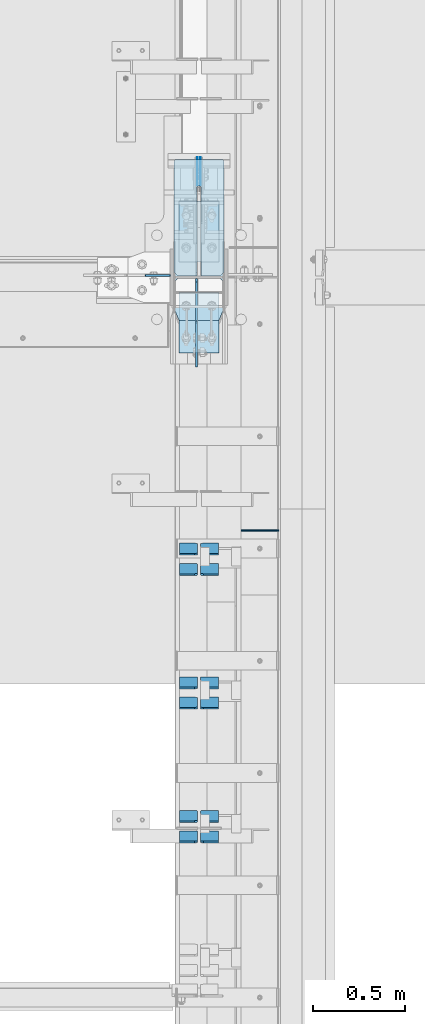
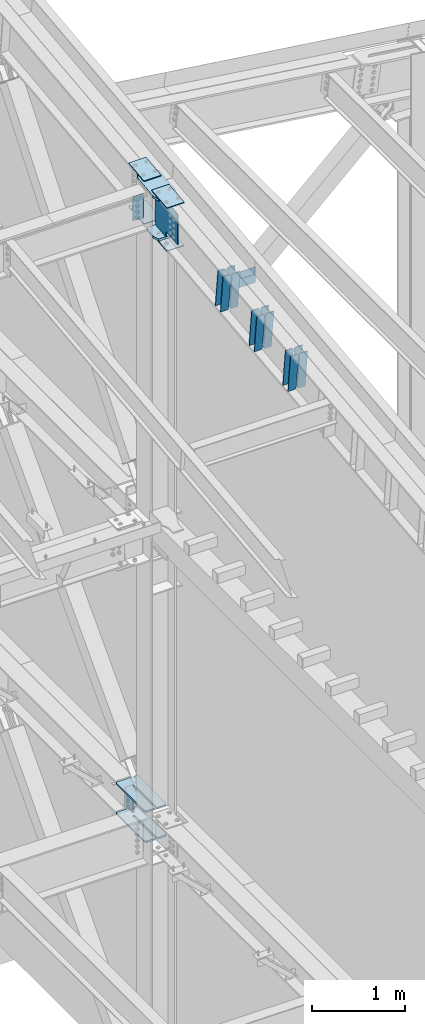
# One storey, part 1044 of 1179: 25 plates, 4 elements without a shape of their own.
"""IFC2X3 building model written with IfcOpenShell, lengths in millimetres."""

from ifc_helpers import new_model, si_unit, frame, origin_with_axes, place, context, subcontext, project, spatial, faceted_brep, material, type_object, element, aggregate, save


model = new_model("IFC2X3")

# Units and contexts
model_context = context("Model", 3, precision=1e-05, world=origin_with_axes())
body_context = subcontext(model_context, "Body", "Model", "MODEL_VIEW")
ifc_project = project(units=[si_unit("LENGTHUNIT", "METRE", prefix="MILLI"), si_unit("AREAUNIT", "SQUARE_METRE"), si_unit("VOLUMEUNIT", "CUBIC_METRE"), si_unit("MASSUNIT", "GRAM", prefix="KILO"), si_unit("TIMEUNIT", "SECOND"), si_unit("PLANEANGLEUNIT", "RADIAN"), si_unit("SOLIDANGLEUNIT", "STERADIAN"), si_unit("THERMODYNAMICTEMPERATUREUNIT", "DEGREE_CELSIUS"), si_unit("LUMINOUSINTENSITYUNIT", "LUMEN")], contexts=[model_context])

# Site, building, storey
site_placement = place(None, origin_with_axes())
site = spatial("IfcSite", under=ifc_project, at=site_placement, CompositionType="ELEMENT")
building_placement = place(site_placement, origin_with_axes())
building = spatial("IfcBuilding", under=site, at=building_placement, Name="Undefined", CompositionType="ELEMENT")
storey_placement = place(building_placement, origin_with_axes())
storey = spatial("IfcBuildingStorey", under=building, at=storey_placement, Name="Undefined", CompositionType="ELEMENT", Elevation=0.0)

# Assembly, plates
assembly_1_placement = place(storey_placement, origin_with_axes())
assembly_1 = element("IfcElementAssembly", 1, at=assembly_1_placement, inside=storey, Name="COLUMN", AssemblyPlace="NOTDEFINED", PredefinedType="RIGID_FRAME")
ifc_material_1 = material(Name="STEEL/A572-GR.50")
plate_type_1 = type_object("IfcPlateType", PredefinedType="NOTDEFINED")
plate_1_placement = place(assembly_1_placement, frame((24171.275012207, 27690.983001131, 3694.1125), z_axis=(0.0, -1.0, 0.0), x_axis=(1.0, 0.0, 0.0)))
plate_1 = element("IfcPlate", 2, at=plate_1_placement, type_object=plate_type_1, material=ifc_material_1, Name="PLATE", context=body_context, shape_type="Brep", body=[
    faceted_brep([(125.412487792972, -11.1125000000002, 633.633001130984), (125.412487792968, -11.1125000000002, 153.987500190735), (125.412487792968, 11.1125000000002, 153.987500190735), (125.412487792972, 11.1125000000002, 633.633001130984), (126.258376502454, -11.1125000000002, 149.734930475586), (126.258376502454, 11.1125000000002, 149.734930475586), (128.667263742896, -11.1125000000002, 146.12977594993), (128.667263742896, 11.1125000000002, 146.12977594993), (132.272418268556, -11.1125000000002, 143.720888709488), (132.272418268556, 11.1125000000002, 143.720888709488), (136.524987602239, -11.1125000000002, 142.875), (136.524987602239, 11.1125000000002, 142.875), (140.777557317386, -11.1125000000002, 143.720888709488), (140.777557317386, 11.1125000000002, 143.720888709488), (144.382711843045, -11.1125000000002, 146.12977594993), (144.382711843045, 11.1125000000002, 146.12977594993), (146.791599083488, -11.1125000000002, 149.734930475586), (146.791599083488, 11.1125000000002, 149.734930475586), (147.637487792974, -11.1125000000002, 153.987500190735), (147.637487792974, 11.1125000000002, 153.987500190735), (147.637487792977, -11.1125000000002, 633.633001130984), (147.637487792977, 11.1125000000002, 633.633001130984), (0.0, -11.1125000000002, 611.408000749514), (22.2250003814697, -11.1125000000002, 633.633001130984), (22.2250003814697, 11.1125000000002, 633.633001130984), (0.0, 11.1125000000002, 611.408000749514), (0.0, -11.1125000000002, 15.875), (0.0, 11.1125000000002, 15.875), (6.34999990463257, -11.1125000000002, 0.0), (6.34999990463257, 11.1125000000002, 0.0), (266.699987888336, -11.1125000000002, 0.0), (266.699987888336, 11.1125000000002, 0.0), (273.049987792969, -11.1125000000002, 15.875), (273.049987792969, 11.1125000000002, 15.875), (273.049987792969, -11.1125000000002, 611.408000749514), (273.049987792969, 11.1125000000002, 611.408000749514), (250.824987411499, -11.1125000000002, 633.633001130984), (250.824987411499, 11.1125000000002, 633.633001130984)], [[[0, 1, 2, 3]], [[4, 5, 2, 1]], [[6, 7, 5, 4]], [[8, 9, 7, 6]], [[10, 11, 9, 8]], [[12, 13, 11, 10]], [[14, 15, 13, 12]], [[16, 17, 15, 14]], [[18, 19, 17, 16]], [[20, 21, 19, 18]], [[22, 23, 24, 25]], [[26, 22, 25, 27]], [[28, 26, 27, 29]], [[30, 28, 29, 31]], [[32, 30, 31, 33]], [[34, 32, 33, 35]], [[36, 34, 35, 37]], [[16, 14, 12, 10, 8, 6, 4, 1, 0, 23, 22, 26, 28, 30, 32, 34, 36, 20, 18]], [[24, 23, 0, 3]], [[37, 35, 33, 31, 29, 27, 25, 24, 3, 2, 5, 7, 9, 11, 13, 15, 17, 19, 21]], [[36, 37, 21, 20]]]),
])
plate_2_placement = place(assembly_1_placement, frame((24171.275012207, 27690.983001131, 4090.9875), z_axis=(0.0, -1.0, 0.0), x_axis=(1.0, 0.0, 0.0)))
plate_2 = element("IfcPlate", 3, at=plate_2_placement, type_object=plate_type_1, material=ifc_material_1, Name="PLATE", context=body_context, shape_type="Brep", body=[
    faceted_brep([(125.412487792972, -11.1125000000002, 633.633001130984), (125.412487792968, -11.1125000000002, 153.987500190735), (125.412487792968, 11.1125000000002, 153.987500190735), (125.412487792972, 11.1125000000002, 633.633001130984), (126.258376502454, -11.1125000000002, 149.734930475586), (126.258376502454, 11.1125000000002, 149.734930475586), (128.667263742896, -11.1125000000002, 146.12977594993), (128.667263742896, 11.1125000000002, 146.12977594993), (132.272418268556, -11.1125000000002, 143.720888709488), (132.272418268556, 11.1125000000002, 143.720888709488), (136.524987602239, -11.1125000000002, 142.875), (136.524987602239, 11.1125000000002, 142.875), (140.777557317386, -11.1125000000002, 143.720888709488), (140.777557317386, 11.1125000000002, 143.720888709488), (144.382711843045, -11.1125000000002, 146.12977594993), (144.382711843045, 11.1125000000002, 146.12977594993), (146.791599083488, -11.1125000000002, 149.734930475586), (146.791599083488, 11.1125000000002, 149.734930475586), (147.637487792974, -11.1125000000002, 153.987500190735), (147.637487792974, 11.1125000000002, 153.987500190735), (147.637487792977, -11.1125000000002, 633.633001130984), (147.637487792977, 11.1125000000002, 633.633001130984), (0.0, -11.1125000000002, 611.408000749514), (22.2250003814697, -11.1125000000002, 633.633001130984), (22.2250003814697, 11.1125000000002, 633.633001130984), (0.0, 11.1125000000002, 611.408000749514), (0.0, -11.1125000000002, 15.875), (0.0, 11.1125000000002, 15.875), (6.34999990463257, -11.1125000000002, 0.0), (6.34999990463257, 11.1125000000002, 0.0), (266.699987888336, -11.1125000000002, 0.0), (266.699987888336, 11.1125000000002, 0.0), (273.049987792969, -11.1125000000002, 15.875), (273.049987792969, 11.1125000000002, 15.875), (273.049987792969, -11.1125000000002, 611.408000749514), (273.049987792969, 11.1125000000002, 611.408000749514), (250.824987411499, -11.1125000000002, 633.633001130984), (250.824987411499, 11.1125000000002, 633.633001130984)], [[[0, 1, 2, 3]], [[4, 5, 2, 1]], [[6, 7, 5, 4]], [[8, 9, 7, 6]], [[10, 11, 9, 8]], [[12, 13, 11, 10]], [[14, 15, 13, 12]], [[16, 17, 15, 14]], [[18, 19, 17, 16]], [[20, 21, 19, 18]], [[22, 23, 24, 25]], [[26, 22, 25, 27]], [[28, 26, 27, 29]], [[30, 28, 29, 31]], [[32, 30, 31, 33]], [[34, 32, 33, 35]], [[36, 34, 35, 37]], [[16, 14, 12, 10, 8, 6, 4, 1, 0, 23, 22, 26, 28, 30, 32, 34, 36, 20, 18]], [[24, 23, 0, 3]], [[37, 35, 33, 31, 29, 27, 25, 24, 3, 2, 5, 7, 9, 11, 13, 15, 17, 19, 21]], [[36, 37, 21, 20]]]),
])
ifc_material_2 = material(Name="STEEL/A36")
plate_type_2 = type_object("IfcPlateType", PredefinedType="NOTDEFINED")
plate_3_placement = place(assembly_1_placement, frame((24150.6375, 27061.3187499701, 12224.9406250357), z_axis=(-1.0, 0.0, 0.0), x_axis=(0.0, 0.0, -1.0)))
plate_3 = element("IfcPlate", 4, at=plate_3_placement, type_object=plate_type_2, material=ifc_material_2, Name="PLATE", context=body_context, shape_type="Brep", body=[
    faceted_brep([(0.0, -4.76249999999709, 0.0), (0.0, -4.76250000000073, 133.35), (0.0, 4.76250000000073, 133.35), (0.0, 4.76249999999709, 0.0), (317.5, -4.76250000000073, 133.350000816426), (317.5, 4.76250000000073, 133.350000816426), (317.499990657736, -4.76249999986703, 5.00222085975111e-10), (317.499990657721, 4.76250000013533, 5.00222085975111e-10)], [[[0, 1, 2, 3]], [[1, 4, 5, 2]], [[4, 6, 7, 5]], [[6, 0, 3, 7]], [[5, 7, 3, 2]], [[6, 4, 1, 0]]]),
])

# Assembly, plate
assembly_2_placement = place(storey_placement, origin_with_axes())
assembly_2 = element("IfcElementAssembly", 5, at=assembly_2_placement, inside=storey, Name="BEAM", AssemblyPlace="NOTDEFINED", PredefinedType="RIGID_FRAME")
plate_type_3 = type_object("IfcPlateType", PredefinedType="NOTDEFINED")
plate_4_placement = place(assembly_2_placement, frame((24739.6, 25676.225, 11892.1378746291), z_axis=(0.0, 0.0, -1.0), x_axis=(-1.0, 0.0, 0.0)))
plate_4 = element("IfcPlate", 6, at=plate_4_placement, type_object=plate_type_3, material=ifc_material_2, Name="CAP_PLATE", context=body_context, shape_type="Brep", body=[
    faceted_brep([(0.0, -3.17500000000109, 0.0), (0.0, -3.17499999999927, 204.492999998953), (0.0, 3.17499999999927, 204.492999998953), (0.0, 3.17500000000109, 7.27595761418343e-12), (203.199999999997, -3.17499999999927, 204.492999998953), (203.199999999997, 3.17499999999927, 204.492999998953), (203.199999999997, -3.17499999999927, 3.63797880709171e-12), (203.199999999997, 3.17499999999382, -3.63797880709171e-12)], [[[0, 1, 2, 3]], [[1, 4, 5, 2]], [[4, 6, 7, 5]], [[6, 0, 3, 7]], [[5, 7, 3, 2]], [[6, 4, 1, 0]]]),
])
aggregate(assembly_2, [plate_4])

# Plate
plate_type_4 = type_object("IfcPlateType", PredefinedType="NOTDEFINED")
plate_5_placement = place(assembly_1_placement, frame((24171.2749999998, 26814.313913095, 12262.513158819), z_axis=(1.0, 0.0, 0.0), x_axis=(0.0, 0.993683229349742, 0.112221387039499)))
plate_5 = element("IfcPlate", 7, at=plate_5_placement, type_object=plate_type_4, material=ifc_material_1, Name="PLATE", context=body_context, shape_type="Brep", body=[
    faceted_brep([(404.009737741189, -14.2874999996602, 8.31619217933621e-11), (71.43750000002, -14.287499999984, 2.90469870378729e-11), (71.4375000000155, 14.2874999999949, 2.90469870378729e-11), (404.009737741166, 14.2875000003405, 8.31619217933621e-11), (477.034739267168, 14.2875000004005, 30.162500381568), (473.810043726306, -14.287499999602, 28.8305609300143), (477.034739268025, 14.2875000004024, 242.887499623284), (473.810043726306, -14.287499999602, 244.219439075195), (404.009737742264, 14.2875000003405, 273.05000000474), (404.00973774229, -14.2874999996602, 273.05000000474), (71.4375000016116, -14.2874999999858, 273.049999999798), (71.4375000016071, 14.2874999999967, 273.049999999798), (4.20644072178584, 14.2875000000058, 244.663552394444), (0.979329666730337, -14.2874999999967, 243.30099437618), (0.979329666730337, -14.2874999999967, 29.7490056281208), (4.20644072178584, 14.2875000000058, 28.3864476098539)], [[[0, 1, 2, 3]], [[0, 3, 4, 5]], [[5, 4, 6, 7]], [[8, 9, 7, 6]], [[10, 9, 8, 11]], [[10, 11, 12, 13]], [[1, 0, 5, 7, 9, 10, 13, 14]], [[2, 1, 14, 15]], [[11, 8, 6, 4, 3, 2, 15, 12]], [[14, 13, 12, 15]]]),
])

# Assembly, plates
assembly_3_placement = place(storey_placement, origin_with_axes())
assembly_3 = element("IfcElementAssembly", 8, at=assembly_3_placement, inside=storey, Name="BEAM", AssemblyPlace="NOTDEFINED", PredefinedType="RIGID_FRAME")
plate_type_5 = type_object("IfcPlateType", PredefinedType="NOTDEFINED")
plate_6_placement = place(assembly_3_placement, frame((24300.65625, 27703.683001131, 4044.95), z_axis=(0.0, 0.0, -1.0), x_axis=(0.0, -1.0, 0.0)))
plate_6 = element("IfcPlate", 9, at=plate_6_placement, type_object=plate_type_5, material=ifc_material_1, Name="PLATE", context=body_context, shape_type="Brep", body=[
    faceted_brep([(3.63797880709171e-12, -1.58750000000055, 1.81898940354586e-12), (-2.18278728425503e-11, -1.58750000000146, 304.8), (-2.18278728425503e-11, 1.58750000000146, 304.8), (-3.63797880709171e-12, 1.58750000000055, 0.0), (152.399999999994, -1.58750000000146, 304.8), (152.399999999994, 1.58750000000146, 304.8), (152.399999999994, -1.58750000000146, 0.0), (152.399999999994, 1.58750000000146, 0.0)], [[[0, 1, 2, 3]], [[1, 4, 5, 2]], [[4, 6, 7, 5]], [[6, 0, 3, 7]], [[5, 7, 3, 2]], [[6, 4, 1, 0]]]),
])
plate_7_placement = place(assembly_3_placement, frame((24314.94375, 27703.683001131, 4044.95), z_axis=(0.0, 0.0, -1.0), x_axis=(0.0, -1.0, 0.0)))
plate_7 = element("IfcPlate", 10, at=plate_7_placement, type_object=plate_type_5, material=ifc_material_1, Name="PLATE", context=body_context, shape_type="Brep", body=[
    faceted_brep([(3.63797880709171e-12, -1.58750000000055, 1.81898940354586e-12), (-2.18278728425503e-11, -1.58750000000146, 304.8), (-2.18278728425503e-11, 1.58750000000146, 304.8), (-3.63797880709171e-12, 1.58750000000055, 0.0), (152.399999999994, -1.58750000000146, 304.8), (152.399999999994, 1.58750000000146, 304.8), (152.399999999994, -1.58750000000146, 0.0), (152.399999999994, 1.58750000000146, 0.0)], [[[0, 1, 2, 3]], [[1, 4, 5, 2]], [[4, 6, 7, 5]], [[6, 0, 3, 7]], [[5, 7, 3, 2]], [[6, 4, 1, 0]]]),
])
aggregate(assembly_3, [plate_6, plate_7])

# Plate
plate_type_6 = type_object("IfcPlateType", PredefinedType="NOTDEFINED")
plate_8_placement = place(assembly_1_placement, frame((24199.850003078, 27462.0732407573, 12356.4484011609), z_axis=(1.0, 0.0, 0.0), x_axis=(0.0, -0.993676146336441, -0.112284087038017)))
plate_8 = element("IfcPlate", 11, at=plate_8_placement, type_object=plate_type_6, material=ifc_material_1, Name="PLATE", context=body_context, shape_type="Brep", body=[
    faceted_brep([(0.0, -6.34999999999854, 0.0), (0.0, -6.350000000004, 215.899993896484), (0.0, 6.35000000000582, 215.899993896484), (0.0, 6.34999999999854, 0.0), (330.200000001782, -6.34999999994034, 215.899993896483), (330.200000001782, 6.35000000006767, 215.899993896483), (330.200000001782, -6.34999999994034, -1.47792889038101e-12), (330.200000001782, 6.35000000006767, -1.47792889038101e-12)], [[[0, 1, 2, 3]], [[1, 4, 5, 2]], [[4, 6, 7, 5]], [[6, 0, 3, 7]], [[5, 7, 3, 2]], [[6, 4, 1, 0]]]),
])

plate_9_placement = place(assembly_1_placement, frame((24199.8500030614, 27463.4992486585, 11791.0580730736), z_axis=(1.0, 0.0, 0.0), x_axis=(0.0, -0.993676146336441, -0.112284087038017)))
plate_9 = element("IfcPlate", 12, at=plate_9_placement, type_object=plate_type_6, material=ifc_material_1, Name="PLATE", context=body_context, shape_type="Brep", body=[
    faceted_brep([(0.0, -6.34999999999854, 0.0), (0.0, -6.350000000004, 215.899993896484), (0.0, 6.35000000000582, 215.899993896484), (0.0, 6.34999999999854, 0.0), (330.200000001782, -6.34999999994034, 215.899993896483), (330.200000001782, 6.35000000006767, 215.899993896483), (330.200000001782, -6.34999999994034, -1.47792889038101e-12), (330.200000001782, 6.35000000006767, -1.47792889038101e-12)], [[[0, 1, 2, 3]], [[1, 4, 5, 2]], [[4, 6, 7, 5]], [[6, 0, 3, 7]], [[5, 7, 3, 2]], [[6, 4, 1, 0]]]),
])

plate_10_placement = place(assembly_1_placement, frame((24199.8500030684, 26640.0882512744, 12263.5651872294), z_axis=(1.0, 0.0, 0.0), x_axis=(0.0, 0.993676146336441, 0.112284087038017)))
plate_10 = element("IfcPlate", 13, at=plate_10_placement, type_object=plate_type_6, material=ifc_material_1, Name="PLATE", context=body_context, shape_type="Brep", body=[
    faceted_brep([(0.0, -6.34999999999854, 0.0), (0.0, -6.350000000004, 215.899993896484), (0.0, 6.35000000000582, 215.899993896484), (0.0, 6.34999999999854, 0.0), (330.200000001782, -6.34999999994034, 215.899993896483), (330.200000001782, 6.35000000006767, 215.899993896483), (330.200000001782, -6.34999999994034, -1.47792889038101e-12), (330.200000001782, 6.35000000006767, -1.47792889038101e-12)], [[[0, 1, 2, 3]], [[1, 4, 5, 2]], [[4, 6, 7, 5]], [[6, 0, 3, 7]], [[5, 7, 3, 2]], [[6, 4, 1, 0]]]),
])

plate_11_placement = place(assembly_1_placement, frame((24199.8500030415, 26640.7392708393, 11698.0872863537), z_axis=(1.0, 0.0, 0.0), x_axis=(0.0, 0.993676146336441, 0.112284087038017)))
plate_11 = element("IfcPlate", 14, at=plate_11_placement, type_object=plate_type_6, material=ifc_material_1, Name="PLATE", context=body_context, shape_type="Brep", body=[
    faceted_brep([(0.0, -6.34999999999854, 0.0), (0.0, -6.350000000004, 215.899993896484), (0.0, 6.35000000000582, 215.899993896484), (0.0, 6.34999999999854, 0.0), (330.200000001782, -6.34999999994034, 215.899993896483), (330.200000001782, 6.35000000006767, 215.899993896483), (330.200000001782, -6.34999999994034, -1.47792889038101e-12), (330.200000001782, 6.35000000006767, -1.47792889038101e-12)], [[[0, 1, 2, 3]], [[1, 4, 5, 2]], [[4, 6, 7, 5]], [[6, 0, 3, 7]], [[5, 7, 3, 2]], [[6, 4, 1, 0]]]),
])

plate_type_7 = type_object("IfcPlateType", PredefinedType="NOTDEFINED")
plate_12_placement = place(assembly_1_placement, frame((24171.2749999998, 26814.3139131717, 11738.3789032815), z_axis=(1.0, 0.0, 0.0), x_axis=(0.0, 0.993676146336441, 0.112284087038017)))
plate_12 = element("IfcPlate", 15, at=plate_12_placement, type_object=plate_type_7, material=ifc_material_1, Name="PLATE", context=body_context, shape_type="Brep", body=[
    faceted_brep([(207.962499617965, -14.2875000000749, 8.87325768417213e-11), (71.43750000002, -14.287499999984, 2.90469870378729e-11), (71.4375000000155, 14.2874999999949, 2.90469870378729e-11), (207.962499617975, 14.2874999999094, 8.87325768417213e-11), (230.187499999511, -14.287500000084, 22.225000381568), (230.187499999523, 14.2874999999003, 22.225000381568), (230.187500000431, -14.2875000000822, 250.824999623284), (230.187500000442, 14.2874999998985, 250.824999623284), (207.962499619063, -14.2875000000731, 273.050000004745), (207.962499619074, 14.2874999999112, 273.050000004745), (71.4375000016116, -14.2874999999858, 273.049999999798), (71.4375000016071, 14.2874999999967, 273.049999999798), (4.20737223302058, 14.2874999999931, 244.663945699182), (0.978435120117865, -14.2874999999894, 243.300616678719), (0.978435120117865, -14.2874999999894, 29.7493833255772), (4.20737223302058, 14.2874999999931, 28.3860543051127)], [[[0, 1, 2, 3]], [[4, 0, 3, 5]], [[6, 4, 5, 7]], [[8, 6, 7, 9]], [[10, 8, 9, 11]], [[10, 11, 12, 13]], [[1, 0, 4, 6, 8, 10, 13, 14]], [[2, 1, 14, 15]], [[11, 9, 7, 5, 3, 2, 15, 12]], [[14, 13, 12, 15]]]),
])

# Assembly, plates
assembly_4_placement = place(storey_placement, origin_with_axes())
assembly_4 = element("IfcElementAssembly", 16, at=assembly_4_placement, inside=storey, Name="BEAM", AssemblyPlace="NOTDEFINED", PredefinedType="RIGID_FRAME")
plate_type_8 = type_object("IfcPlateType", PredefinedType="NOTDEFINED")
plate_13_placement = place(assembly_4_placement, frame((24414.1625, 24040.3832307645, 11436.2025622401), z_axis=(0.0, -0.112284087038017, 0.993676146336441), x_axis=(-1.0, 0.0, 0.0)))
plate_13 = element("IfcPlate", 17, at=plate_13_placement, type_object=plate_type_8, material=ifc_material_2, Name="PLATE", context=body_context, shape_type="Brep", body=[
    faceted_brep([(0.0, -4.76249999999709, 0.0), (0.0, -4.76250000020082, 498.474999998594), (0.0, 4.76249999979336, 498.474999998596), (0.0, 4.76249999999709, 0.0), (81.7562503814697, -4.76250000020082, 498.474999998594), (81.7562503814697, 4.76249999979336, 498.474999998596), (99.21875, -4.76250000019354, 481.012500380073), (99.21875, 4.76249999980064, 481.012500380079), (99.21875, -4.76250000000437, 17.4624996185212), (99.21875, 4.76249999998981, 17.4624996185248), (81.7562503814697, -4.76250000000073, 0.0), (81.7562503814697, 4.76249999999709, 3.63797880709171e-12)], [[[0, 1, 2, 3]], [[1, 4, 5, 2]], [[4, 6, 7, 5]], [[6, 8, 9, 7]], [[8, 10, 11, 9]], [[10, 0, 3, 11]], [[5, 7, 9, 11, 3, 2]], [[10, 8, 6, 4, 1, 0]]]),
])
plate_14_placement = place(assembly_4_placement, frame((24300.65625, 24040.3832307645, 11436.2025622401), z_axis=(0.0, -0.112284087038017, 0.993676146336441), x_axis=(-1.0, 0.0, 0.0)))
plate_14 = element("IfcPlate", 18, at=plate_14_placement, type_object=plate_type_8, material=ifc_material_2, Name="PLATE", context=body_context, shape_type="Brep", body=[
    faceted_brep([(-1.81898940354586e-12, -4.76249999999345, 17.4624996185303), (0.0, -4.76250000019354, 481.012500380073), (0.0, 4.76249999980064, 481.012500380079), (1.81898940354586e-12, 4.76250000000073, 17.4624996185303), (17.4624996185303, -4.76250000020082, 498.474999998594), (17.4624996185303, 4.76249999979336, 498.474999998596), (99.2187497618652, -4.76249999998072, 498.475), (99.2187499999927, 4.76250000001892, 498.475), (99.21875, -4.76250000000073, 0.0), (99.21875, 4.76249999999709, 3.63797880709171e-12), (17.4624996185157, -4.76250000000073, 0.0), (17.4624996185212, 4.76249999999345, 0.0)], [[[0, 1, 2, 3]], [[1, 4, 5, 2]], [[4, 6, 7, 5]], [[6, 8, 9, 7]], [[8, 10, 11, 9]], [[10, 0, 3, 11]], [[5, 7, 9, 11, 3, 2]], [[10, 8, 6, 4, 1, 0]]]),
])
plate_15_placement = place(assembly_4_placement, frame((24414.1625, 24150.8054925261, 11448.6801314122), z_axis=(0.0, -0.112284087038017, 0.993676146336441), x_axis=(-1.0, 0.0, 0.0)))
plate_15 = element("IfcPlate", 19, at=plate_15_placement, type_object=plate_type_8, material=ifc_material_2, Name="PLATE", context=body_context, shape_type="Brep", body=[
    faceted_brep([(0.0, -4.76249999999709, 0.0), (0.0, -4.76250000020082, 498.474999998594), (0.0, 4.76249999979336, 498.474999998596), (0.0, 4.76249999999709, 0.0), (81.7562503814697, -4.76250000020082, 498.474999998594), (81.7562503814697, 4.76249999979336, 498.474999998596), (99.21875, -4.76250000019354, 481.012500380073), (99.21875, 4.76249999980064, 481.012500380079), (99.21875, -4.76250000000437, 17.4624996185212), (99.21875, 4.76249999998981, 17.4624996185248), (81.7562503814697, -4.76250000000073, 0.0), (81.7562503814697, 4.76249999999709, 3.63797880709171e-12)], [[[0, 1, 2, 3]], [[1, 4, 5, 2]], [[4, 6, 7, 5]], [[6, 8, 9, 7]], [[8, 10, 11, 9]], [[10, 0, 3, 11]], [[5, 7, 9, 11, 3, 2]], [[10, 8, 6, 4, 1, 0]]]),
])
plate_16_placement = place(assembly_4_placement, frame((24300.65625, 24150.8054925261, 11448.6801314122), z_axis=(0.0, -0.112284087038017, 0.993676146336441), x_axis=(-1.0, 0.0, 0.0)))
plate_16 = element("IfcPlate", 20, at=plate_16_placement, type_object=plate_type_8, material=ifc_material_2, Name="PLATE", context=body_context, shape_type="Brep", body=[
    faceted_brep([(-1.81898940354586e-12, -4.76249999999345, 17.4624996185303), (0.0, -4.76250000019354, 481.012500380073), (0.0, 4.76249999980064, 481.012500380079), (1.81898940354586e-12, 4.76250000000073, 17.4624996185303), (17.4624996185303, -4.76250000020082, 498.474999998594), (17.4624996185303, 4.76249999979336, 498.474999998596), (99.2187497618652, -4.76249999998072, 498.475), (99.2187499999927, 4.76250000001892, 498.475), (99.21875, -4.76250000000073, 0.0), (99.21875, 4.76249999999709, 3.63797880709171e-12), (17.4624996185157, -4.76250000000073, 0.0), (17.4624996185212, 4.76249999999345, 0.0)], [[[0, 1, 2, 3]], [[1, 4, 5, 2]], [[4, 6, 7, 5]], [[6, 8, 9, 7]], [[8, 10, 11, 9]], [[10, 0, 3, 11]], [[5, 7, 9, 11, 3, 2]], [[10, 8, 6, 4, 1, 0]]]),
])
plate_17_placement = place(assembly_4_placement, frame((24414.1625, 24766.2899520578, 11518.2290592788), z_axis=(0.0, -0.112284087038017, 0.993676146336441), x_axis=(-1.0, 0.0, 0.0)))
plate_17 = element("IfcPlate", 21, at=plate_17_placement, type_object=plate_type_8, material=ifc_material_2, Name="PLATE", context=body_context, shape_type="Brep", body=[
    faceted_brep([(0.0, -4.76249999999709, 0.0), (0.0, -4.76250000020082, 498.474999998594), (0.0, 4.76249999979336, 498.474999998596), (0.0, 4.76249999999709, 0.0), (81.7562503814697, -4.76250000020082, 498.474999998594), (81.7562503814697, 4.76249999979336, 498.474999998596), (99.21875, -4.76250000019354, 481.012500380073), (99.21875, 4.76249999980064, 481.012500380079), (99.21875, -4.76250000000437, 17.4624996185212), (99.21875, 4.76249999998981, 17.4624996185248), (81.7562503814697, -4.76250000000073, 0.0), (81.7562503814697, 4.76249999999709, 3.63797880709171e-12)], [[[0, 1, 2, 3]], [[1, 4, 5, 2]], [[4, 6, 7, 5]], [[6, 8, 9, 7]], [[8, 10, 11, 9]], [[10, 0, 3, 11]], [[5, 7, 9, 11, 3, 2]], [[10, 8, 6, 4, 1, 0]]]),
])
plate_18_placement = place(assembly_4_placement, frame((24300.65625, 24766.2899520578, 11518.2290592788), z_axis=(0.0, -0.112284087038017, 0.993676146336441), x_axis=(-1.0, 0.0, 0.0)))
plate_18 = element("IfcPlate", 22, at=plate_18_placement, type_object=plate_type_8, material=ifc_material_2, Name="PLATE", context=body_context, shape_type="Brep", body=[
    faceted_brep([(-1.81898940354586e-12, -4.76249999999345, 17.4624996185303), (0.0, -4.76250000019354, 481.012500380073), (0.0, 4.76249999980064, 481.012500380079), (1.81898940354586e-12, 4.76250000000073, 17.4624996185303), (17.4624996185303, -4.76250000020082, 498.474999998594), (17.4624996185303, 4.76249999979336, 498.474999998596), (99.2187497618652, -4.76249999998072, 498.475), (99.2187499999927, 4.76250000001892, 498.475), (99.21875, -4.76250000000073, 0.0), (99.21875, 4.76249999999709, 3.63797880709171e-12), (17.4624996185157, -4.76250000000073, 0.0), (17.4624996185212, 4.76249999999345, 0.0)], [[[0, 1, 2, 3]], [[1, 4, 5, 2]], [[4, 6, 7, 5]], [[6, 8, 9, 7]], [[8, 10, 11, 9]], [[10, 0, 3, 11]], [[5, 7, 9, 11, 3, 2]], [[10, 8, 6, 4, 1, 0]]]),
])
plate_19_placement = place(assembly_4_placement, frame((24414.1625, 24876.7122138194, 11530.7066284509), z_axis=(0.0, -0.112284087038017, 0.993676146336441), x_axis=(-1.0, 0.0, 0.0)))
plate_19 = element("IfcPlate", 23, at=plate_19_placement, type_object=plate_type_8, material=ifc_material_2, Name="PLATE", context=body_context, shape_type="Brep", body=[
    faceted_brep([(0.0, -4.76249999999709, 0.0), (0.0, -4.76250000020082, 498.474999998594), (0.0, 4.76249999979336, 498.474999998596), (0.0, 4.76249999999709, 0.0), (81.7562503814697, -4.76250000020082, 498.474999998594), (81.7562503814697, 4.76249999979336, 498.474999998596), (99.21875, -4.76250000019354, 481.012500380073), (99.21875, 4.76249999980064, 481.012500380079), (99.21875, -4.76250000000437, 17.4624996185212), (99.21875, 4.76249999998981, 17.4624996185248), (81.7562503814697, -4.76250000000073, 0.0), (81.7562503814697, 4.76249999999709, 3.63797880709171e-12)], [[[0, 1, 2, 3]], [[1, 4, 5, 2]], [[4, 6, 7, 5]], [[6, 8, 9, 7]], [[8, 10, 11, 9]], [[10, 0, 3, 11]], [[5, 7, 9, 11, 3, 2]], [[10, 8, 6, 4, 1, 0]]]),
])
plate_20_placement = place(assembly_4_placement, frame((24300.65625, 24876.7122138194, 11530.7066284509), z_axis=(0.0, -0.112284087038017, 0.993676146336441), x_axis=(-1.0, 0.0, 0.0)))
plate_20 = element("IfcPlate", 24, at=plate_20_placement, type_object=plate_type_8, material=ifc_material_2, Name="PLATE", context=body_context, shape_type="Brep", body=[
    faceted_brep([(-1.81898940354586e-12, -4.76249999999345, 17.4624996185303), (0.0, -4.76250000019354, 481.012500380073), (0.0, 4.76249999980064, 481.012500380079), (1.81898940354586e-12, 4.76250000000073, 17.4624996185303), (17.4624996185303, -4.76250000020082, 498.474999998594), (17.4624996185303, 4.76249999979336, 498.474999998596), (99.2187497618652, -4.76249999998072, 498.475), (99.2187499999927, 4.76250000001892, 498.475), (99.21875, -4.76250000000073, 0.0), (99.21875, 4.76249999999709, 3.63797880709171e-12), (17.4624996185157, -4.76250000000073, 0.0), (17.4624996185212, 4.76249999999345, 0.0)], [[[0, 1, 2, 3]], [[1, 4, 5, 2]], [[4, 6, 7, 5]], [[6, 8, 9, 7]], [[8, 10, 11, 9]], [[10, 0, 3, 11]], [[5, 7, 9, 11, 3, 2]], [[10, 8, 6, 4, 1, 0]]]),
])
plate_21_placement = place(assembly_4_placement, frame((24414.1625, 25602.6189244967, 11612.7331242899), z_axis=(0.0, -0.112284087038017, 0.993676146336441), x_axis=(-1.0, 0.0, 0.0)))
plate_21 = element("IfcPlate", 25, at=plate_21_placement, type_object=plate_type_8, material=ifc_material_2, Name="PLATE", context=body_context, shape_type="Brep", body=[
    faceted_brep([(0.0, -4.76249999999709, 0.0), (0.0, -4.76250000020082, 498.474999998594), (0.0, 4.76249999979336, 498.474999998596), (0.0, 4.76249999999709, 0.0), (81.7562503814697, -4.76250000020082, 498.474999998594), (81.7562503814697, 4.76249999979336, 498.474999998596), (99.21875, -4.76250000019354, 481.012500380073), (99.21875, 4.76249999980064, 481.012500380079), (99.21875, -4.76250000000437, 17.4624996185212), (99.21875, 4.76249999998981, 17.4624996185248), (81.7562503814697, -4.76250000000073, 0.0), (81.7562503814697, 4.76249999999709, 3.63797880709171e-12)], [[[0, 1, 2, 3]], [[1, 4, 5, 2]], [[4, 6, 7, 5]], [[6, 8, 9, 7]], [[8, 10, 11, 9]], [[10, 0, 3, 11]], [[5, 7, 9, 11, 3, 2]], [[10, 8, 6, 4, 1, 0]]]),
])
plate_22_placement = place(assembly_4_placement, frame((24300.65625, 25602.6189244967, 11612.7331242899), z_axis=(0.0, -0.112284087038017, 0.993676146336441), x_axis=(-1.0, 0.0, 0.0)))
plate_22 = element("IfcPlate", 26, at=plate_22_placement, type_object=plate_type_8, material=ifc_material_2, Name="PLATE", context=body_context, shape_type="Brep", body=[
    faceted_brep([(-1.81898940354586e-12, -4.76249999999345, 17.4624996185303), (0.0, -4.76250000019354, 481.012500380073), (0.0, 4.76249999980064, 481.012500380079), (1.81898940354586e-12, 4.76250000000073, 17.4624996185303), (17.4624996185303, -4.76250000020082, 498.474999998594), (17.4624996185303, 4.76249999979336, 498.474999998596), (99.2187497618652, -4.76249999998072, 498.475), (99.2187499999927, 4.76250000001892, 498.475), (99.21875, -4.76250000000073, 0.0), (99.21875, 4.76249999999709, 3.63797880709171e-12), (17.4624996185157, -4.76250000000073, 0.0), (17.4624996185212, 4.76249999999345, 0.0)], [[[0, 1, 2, 3]], [[1, 4, 5, 2]], [[4, 6, 7, 5]], [[6, 8, 9, 7]], [[8, 10, 11, 9]], [[10, 0, 3, 11]], [[5, 7, 9, 11, 3, 2]], [[10, 8, 6, 4, 1, 0]]]),
])
plate_23_placement = place(assembly_4_placement, frame((24414.1625, 25492.1966627351, 11600.2555551179), z_axis=(0.0, -0.112284087038017, 0.993676146336441), x_axis=(-1.0, 0.0, 0.0)))
plate_23 = element("IfcPlate", 27, at=plate_23_placement, type_object=plate_type_8, material=ifc_material_2, Name="PLATE", context=body_context, shape_type="Brep", body=[
    faceted_brep([(0.0, -4.76249999999709, 0.0), (0.0, -4.76250000020082, 498.474999998594), (0.0, 4.76249999979336, 498.474999998596), (0.0, 4.76249999999709, 0.0), (81.7562503814697, -4.76250000020082, 498.474999998594), (81.7562503814697, 4.76249999979336, 498.474999998596), (99.21875, -4.76250000019354, 481.012500380073), (99.21875, 4.76249999980064, 481.012500380079), (99.21875, -4.76250000000437, 17.4624996185212), (99.21875, 4.76249999998981, 17.4624996185248), (81.7562503814697, -4.76250000000073, 0.0), (81.7562503814697, 4.76249999999709, 3.63797880709171e-12)], [[[0, 1, 2, 3]], [[1, 4, 5, 2]], [[4, 6, 7, 5]], [[6, 8, 9, 7]], [[8, 10, 11, 9]], [[10, 0, 3, 11]], [[5, 7, 9, 11, 3, 2]], [[10, 8, 6, 4, 1, 0]]]),
])
plate_24_placement = place(assembly_4_placement, frame((24300.65625, 25492.1966627351, 11600.2555551179), z_axis=(0.0, -0.112284087038017, 0.993676146336441), x_axis=(-1.0, 0.0, 0.0)))
plate_24 = element("IfcPlate", 28, at=plate_24_placement, type_object=plate_type_8, material=ifc_material_2, Name="PLATE", context=body_context, shape_type="Brep", body=[
    faceted_brep([(-1.81898940354586e-12, -4.76249999999345, 17.4624996185303), (0.0, -4.76250000019354, 481.012500380073), (0.0, 4.76249999980064, 481.012500380079), (1.81898940354586e-12, 4.76250000000073, 17.4624996185303), (17.4624996185303, -4.76250000020082, 498.474999998594), (17.4624996185303, 4.76249999979336, 498.474999998596), (99.2187497618652, -4.76249999998072, 498.475), (99.2187499999927, 4.76250000001892, 498.475), (99.21875, -4.76250000000073, 0.0), (99.21875, 4.76249999999709, 3.63797880709171e-12), (17.4624996185157, -4.76250000000073, 0.0), (17.4624996185212, 4.76249999999345, 0.0)], [[[0, 1, 2, 3]], [[1, 4, 5, 2]], [[4, 6, 7, 5]], [[6, 8, 9, 7]], [[8, 10, 11, 9]], [[10, 0, 3, 11]], [[5, 7, 9, 11, 3, 2]], [[10, 8, 6, 4, 1, 0]]]),
])
aggregate(assembly_4, [plate_13, plate_14, plate_15, plate_16, plate_17, plate_18, plate_19, plate_20, plate_21, plate_22, plate_23, plate_24])

# Plate
plate_type_9 = type_object("IfcPlateType", PredefinedType="NOTDEFINED")
plate_25_placement = place(assembly_1_placement, frame((24294.30625, 27044.6499999769, 11797.4396066718), z_axis=(0.0, -0.743858433013958, 0.668337214012522), x_axis=(0.0, -0.668337214012522, -0.743858433013957)))
plate_25 = element("IfcPlate", 29, at=plate_25_placement, type_object=plate_type_9, material=ifc_material_1, Name="PLATE", context=body_context, shape_type="Brep", body=[
    faceted_brep([(-340.425158086084, -6.34999999999854, 331.31098111851), (-340.36891654725, 6.34999999999854, 331.247674275044), (-340.496288379261, 6.35000000000002, 305.926948789638), (-340.496288379261, -6.35000000000002, 305.926948789638), (28.5035613092805, -6.35000000000002, -1.04591890703887e-11), (0.0, -6.34999999999854, 0.0), (0.0, 6.34999999999854, 0.0), (28.5035613092805, 6.35000000000002, -1.04591890703887e-11), (185.535041792471, -6.35000000000002, 139.488379402524), (185.535041792471, 6.35000000000002, 139.488379402524), (150.391206739107, -6.35000000000002, 171.064189752232), (150.391206739107, 6.35000000000002, 171.064189752232), (145.102749755571, -6.35000000000002, 177.732630246504), (145.102749755571, 6.35000000000002, 177.732630246504), (142.314026896069, -6.35000000000002, 185.773706089029), (142.314026896069, 6.35000000000002, 185.773706089029), (142.338144349787, -6.35000000000002, 194.28459877081), (142.338144349787, 6.35000000000002, 194.28459877081), (145.172394309466, -6.35000000000002, 202.30974070466), (145.172394309466, 6.35000000000002, 202.30974070466), (150.498558992693, -6.35000000000002, 208.948102374491), (150.498558992693, 6.35000000000002, 208.948102374491), (319.572465694362, -6.35000000000002, 359.133576332748), (319.572465694362, 6.35000000000002, 359.133576332748), (24.8516291671876, -6.35000000000002, 623.932487042394), (24.8516291671876, 6.35000000000002, 623.932487042394), (-148.513946545472, -6.35000000000002, 469.934796538949), (-148.513946545472, 6.35000000000002, 469.934796538949), (-156.393362644572, -6.35000000000002, 465.168486686387), (-156.393362644572, 6.35000000000002, 465.168486686387), (-165.454335371476, -6.35000000000002, 463.524807607098), (-165.454335371476, 6.35000000000002, 463.524807607098), (-174.505847216309, -6.35000000000002, 465.219812325748), (-174.505847216309, 6.35000000000002, 465.219812325748), (-182.358124252696, -6.35000000000002, 470.030701330617), (-182.358124252696, 6.35000000000002, 470.030701330617), (-183.249688243475, 6.35000000000002, 470.831748115088), (-183.249688243475, -6.35000000000002, 470.831748115088)], [[[0, 1, 2, 3]], [[4, 5, 6, 7]], [[8, 4, 7, 9]], [[10, 8, 9, 11]], [[12, 10, 11, 13]], [[14, 12, 13, 15]], [[16, 14, 15, 17]], [[18, 16, 17, 19]], [[20, 18, 19, 21]], [[22, 20, 21, 23]], [[24, 22, 23, 25]], [[26, 24, 25, 27]], [[28, 26, 27, 29]], [[30, 28, 29, 31]], [[32, 30, 31, 33]], [[34, 32, 33, 35]], [[34, 35, 36, 37]], [[5, 4, 8, 10, 12, 14, 16, 18, 20, 22, 24, 26, 28, 30, 32, 34, 37, 0, 3]], [[6, 5, 3, 2]], [[36, 35, 33, 31, 29, 27, 25, 23, 21, 19, 17, 15, 13, 11, 9, 7, 6, 2, 1]], [[37, 36, 1, 0]]]),
])

aggregate(assembly_1, [plate_1, plate_2, plate_3, plate_5, plate_8, plate_9, plate_10, plate_11, plate_12, plate_25])

save(model, "model.ifc")
